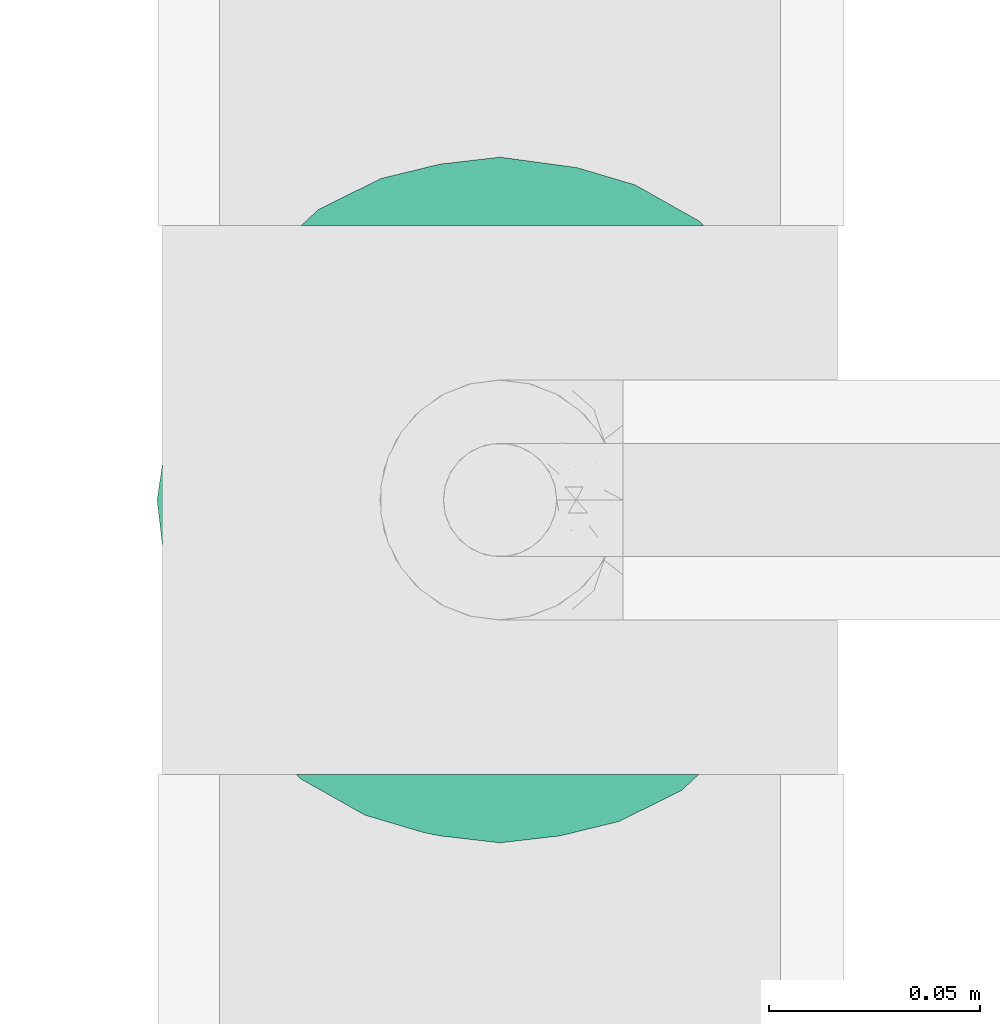
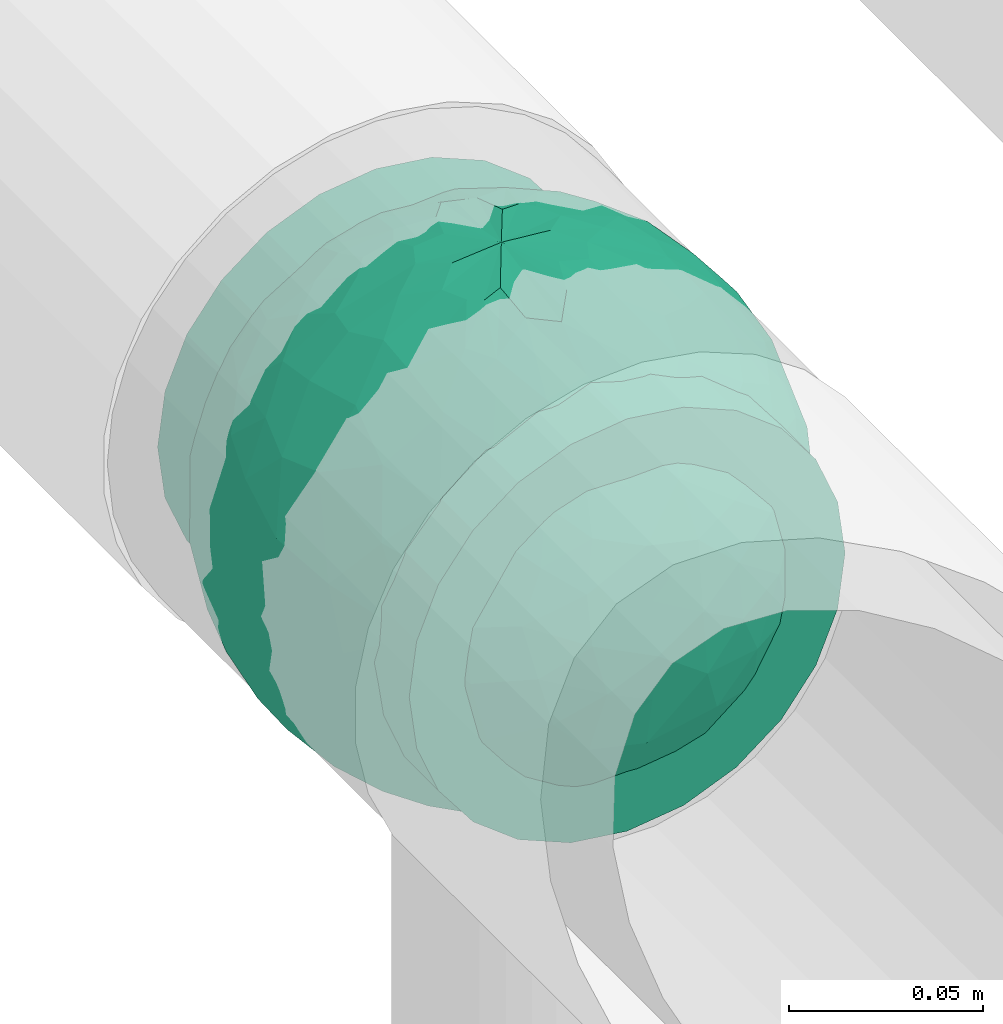
# One storey, part 807 of 827: 1 flow fitting.
"""IFC2X3 building model written with IfcOpenShell, lengths in millimetres."""

from ifc_helpers import new_model, entity, si_unit, converted_unit, derived_unit, direction, frame, origin, place, context, subcontext, project, spatial, faceted_brep, source, transform, mapped, material, material_list, type_object, type_shapes, element, save


model = new_model("IFC2X3")

# Units and contexts
model_context = context("Model", 3, precision=0.01, world=origin(), true_north=direction((6.12303176911189e-17, 1.0)))
body_context = subcontext(model_context, "Body", "Model", "MODEL_VIEW")
ifc_project = project(units=[si_unit("LENGTHUNIT", "METRE", prefix="MILLI"), si_unit("AREAUNIT", "SQUARE_METRE"), si_unit("VOLUMEUNIT", "CUBIC_METRE"), converted_unit("PLANEANGLEUNIT", "DEGREE", entity("IfcRatioMeasure", 0.0174532925199433), si_unit("PLANEANGLEUNIT", "RADIAN"), dimensions=[0, 0, 0, 0, 0, 0, 0]), si_unit("MASSUNIT", "GRAM", prefix="KILO"), derived_unit("MASSDENSITYUNIT", [(si_unit("MASSUNIT", "GRAM", prefix="KILO"), 1), (si_unit("LENGTHUNIT", "METRE"), -3)]), derived_unit("MOMENTOFINERTIAUNIT", [(si_unit("LENGTHUNIT", "METRE"), 4)]), si_unit("TIMEUNIT", "SECOND"), si_unit("FREQUENCYUNIT", "HERTZ"), si_unit("THERMODYNAMICTEMPERATUREUNIT", "DEGREE_CELSIUS"), derived_unit("THERMALTRANSMITTANCEUNIT", [(si_unit("MASSUNIT", "GRAM", prefix="KILO"), 1), (si_unit("THERMODYNAMICTEMPERATUREUNIT", "KELVIN"), -1), (si_unit("TIMEUNIT", "SECOND"), -3)]), derived_unit("VOLUMETRICFLOWRATEUNIT", [(si_unit("LENGTHUNIT", "METRE"), 3), (si_unit("TIMEUNIT", "SECOND"), -1)]), derived_unit("MASSFLOWRATEUNIT", [(si_unit("MASSUNIT", "GRAM", prefix="KILO"), 1), (si_unit("TIMEUNIT", "SECOND"), -1)]), derived_unit("ROTATIONALFREQUENCYUNIT", [(si_unit("TIMEUNIT", "SECOND"), -1)]), si_unit("ELECTRICCURRENTUNIT", "AMPERE"), si_unit("ELECTRICVOLTAGEUNIT", "VOLT"), si_unit("POWERUNIT", "WATT"), si_unit("FORCEUNIT", "NEWTON", prefix="KILO"), si_unit("ILLUMINANCEUNIT", "LUX"), si_unit("LUMINOUSFLUXUNIT", "LUMEN"), si_unit("LUMINOUSINTENSITYUNIT", "CANDELA"), derived_unit("USERDEFINED", [(si_unit("MASSUNIT", "GRAM", prefix="KILO"), -1), (si_unit("LENGTHUNIT", "METRE"), -2), (si_unit("TIMEUNIT", "SECOND"), 3), (si_unit("LUMINOUSFLUXUNIT", "LUMEN"), 1)]), derived_unit("LINEARVELOCITYUNIT", [(si_unit("LENGTHUNIT", "METRE"), 1), (si_unit("TIMEUNIT", "SECOND"), -1)]), si_unit("PRESSUREUNIT", "PASCAL"), derived_unit("USERDEFINED", [(si_unit("LENGTHUNIT", "METRE"), -2), (si_unit("MASSUNIT", "GRAM", prefix="KILO"), 1), (si_unit("TIMEUNIT", "SECOND"), -2)]), derived_unit("LINEARFORCEUNIT", [(si_unit("MASSUNIT", "GRAM", prefix="KILO"), 1), (si_unit("LENGTHUNIT", "METRE"), 1), (si_unit("TIMEUNIT", "SECOND"), -2), (si_unit("LENGTHUNIT", "METRE"), -1)]), derived_unit("PLANARFORCEUNIT", [(si_unit("MASSUNIT", "GRAM", prefix="KILO"), 1), (si_unit("LENGTHUNIT", "METRE"), 1), (si_unit("TIMEUNIT", "SECOND"), -2), (si_unit("LENGTHUNIT", "METRE"), -2)])], contexts=[model_context])

# Site, building, storey
site_placement = place(None, origin())
site = spatial("IfcSite", under=ifc_project, at=site_placement, CompositionType="ELEMENT")
building_placement = place(site_placement, origin())
building = spatial("IfcBuilding", under=site, at=building_placement, CompositionType="ELEMENT")
storey_placement = place(building_placement, frame((0.0, 0.0, 28200.0)))
storey = spatial("IfcBuildingStorey", under=building, at=storey_placement, Name="08", CompositionType="ELEMENT", Elevation=28200.0)

# Flow fitting
ifc_material_1 = material()
ifc_material_2 = material(Name="ADSK_")
ifc_material_list = material_list([ifc_material_1, ifc_material_2])
pipe_fitting_type = type_object("IfcPipeFittingType", Name="ADSK_1", PredefinedType="NOTDEFINED", material=ifc_material_list)
shared_shape = source(origin(), body_context, "Body", "Brep", [
    faceted_brep([(-65.0, 32.5, -56.29), (-65.0, 16.82, -62.79), (-65.0, 0.0, -65.0), (-65.0, -16.82, -62.79), (-65.0, -32.5, -56.29), (-65.0, -45.96, -45.96), (-65.0, -56.29, -32.5), (-65.0, -62.79, -16.82), (-65.0, -65.0, 0.0), (-65.0, -62.79, 16.82), (-65.0, -56.29, 32.5), (-65.0, -45.96, 45.96), (-65.0, -32.5, 56.29), (-65.0, -16.82, 62.79), (-65.0, 0.0, 65.0), (-65.0, 16.82, 62.79), (-65.0, 32.5, 56.29), (-65.0, 45.96, 45.96), (-65.0, 56.29, 32.5), (-65.0, 62.79, 16.82), (-65.0, 65.0, 0.0), (-65.0, 62.79, -16.82), (-65.0, 56.29, -32.5), (-65.0, 45.96, -45.96), (65.0, 0.0, -65.0), (65.0, 16.82, -62.79), (65.0, 32.5, -56.29), (65.0, 45.96, -45.96), (65.0, 56.29, -32.5), (65.0, 62.79, -16.82), (65.0, 65.0, 0.0), (65.0, 62.79, 16.82), (65.0, 56.29, 32.5), (65.0, 45.96, 45.96), (65.0, 32.5, 56.29), (65.0, 16.82, 62.79), (65.0, 0.0, 65.0), (65.0, -16.82, 62.79), (65.0, -32.5, 56.29), (65.0, -45.96, 45.96), (65.0, -56.29, 32.5), (65.0, -62.79, 16.82), (65.0, -65.0, 0.0), (65.0, -62.79, -16.82), (65.0, -56.29, -32.5), (65.0, -45.96, -45.96), (65.0, -32.5, -56.29), (65.0, -16.82, -62.79), (12.5, -65.0, 0.0), (11.74, -64.86, 4.28), (9.57, -64.5, 8.04), (2.17, -63.82, 12.31), (6.26, -64.09, 10.82), (-11.74, -64.86, 4.28), (-9.58, -64.5, 8.03), (-12.5, -65.0, 0.0), (-6.26, -64.09, 10.82), (-2.18, -63.82, 12.31), (2.17, -63.82, -12.31), (6.26, -64.09, -10.82), (11.74, -64.86, -4.28), (9.57, -64.5, -8.04), (-2.18, -63.82, -12.31), (-6.26, -64.09, -10.82), (-9.58, -64.5, -8.03), (-11.74, -64.86, -4.28), (3.24, -70.0, -12.07), (6.25, -70.0, -10.83), (8.84, -70.0, -8.84), (10.83, -70.0, -6.25), (12.07, -70.0, -3.24), (12.5, -70.0, 0.0), (12.07, -70.0, 3.24), (10.83, -70.0, 6.25), (8.84, -70.0, 8.84), (6.25, -70.0, 10.83), (3.24, -70.0, 12.07), (0.0, -70.0, 12.5), (-3.24, -70.0, 12.07), (-6.25, -70.0, 10.83), (-8.84, -70.0, 8.84), (-10.83, -70.0, 6.25), (-12.07, -70.0, 3.24), (-12.5, -70.0, 0.0), (-12.07, -70.0, -3.24), (-10.83, -70.0, -6.25), (-8.84, -70.0, -8.84), (-6.25, -70.0, -10.83), (-3.24, -70.0, -12.07), (0.0, -70.0, -12.5)], [[[0, 1, 2, 3, 4, 5, 6, 7, 8, 9, 10, 11, 12, 13, 14, 15, 16, 17, 18, 19, 20, 21, 22, 23]], [[24, 25, 26, 27, 28, 29, 30, 31, 32, 33, 34, 35, 36, 37, 38, 39, 40, 41, 42, 43, 44, 45, 46, 47]], [[48, 42, 49]], [[50, 49, 42]], [[42, 41, 50]], [[51, 40, 10]], [[52, 41, 51]], [[41, 52, 50]], [[51, 41, 40]], [[40, 39, 11, 10]], [[53, 54, 8]], [[8, 55, 53]], [[54, 9, 8]], [[56, 57, 9]], [[57, 10, 9]], [[57, 51, 10]], [[56, 9, 54]], [[39, 38, 12, 11]], [[14, 13, 37, 36]], [[13, 12, 38, 37]], [[15, 14, 36, 35]], [[32, 31, 19, 18]], [[17, 16, 34, 33]], [[18, 17, 33, 32]], [[35, 34, 16, 15]], [[20, 19, 31, 30]], [[20, 30, 29, 21]], [[22, 28, 27, 23]], [[21, 29, 28, 22]], [[24, 47, 3, 2]], [[1, 0, 26, 25]], [[2, 1, 25, 24]], [[26, 0, 23, 27]], [[46, 4, 3, 47]], [[46, 45, 5, 4]], [[44, 43, 58]], [[6, 44, 58]], [[44, 6, 5, 45]], [[43, 59, 58]], [[42, 48, 60]], [[59, 43, 61]], [[60, 61, 42]], [[61, 43, 42]], [[6, 58, 62]], [[7, 6, 62]], [[62, 63, 7]], [[64, 8, 7]], [[65, 55, 8]], [[65, 8, 64]], [[64, 7, 63]], [[66, 67, 68, 69, 70, 71, 72, 73, 74, 75, 76, 77, 78, 79, 80, 81, 82, 83, 84, 85, 86, 87, 88, 89]], [[83, 82, 55]], [[80, 79, 53]], [[81, 80, 53]], [[82, 81, 53]], [[55, 82, 53]], [[53, 79, 54]], [[57, 56, 52]], [[54, 77, 56]], [[78, 77, 54]], [[78, 54, 79]], [[76, 75, 50]], [[77, 76, 50]], [[73, 72, 49]], [[74, 73, 49]], [[75, 74, 49]], [[77, 50, 52]], [[51, 57, 52]], [[72, 48, 49]], [[49, 50, 75]], [[72, 71, 48]], [[52, 56, 77]], [[71, 70, 48]], [[68, 67, 60]], [[69, 68, 60]], [[70, 69, 60]], [[48, 70, 60]], [[60, 67, 61]], [[58, 59, 62]], [[61, 89, 59]], [[66, 89, 61]], [[66, 61, 67]], [[88, 87, 64]], [[89, 88, 64]], [[85, 84, 65]], [[86, 85, 65]], [[87, 86, 65]], [[89, 64, 63]], [[62, 59, 63]], [[84, 55, 65]], [[65, 64, 87]], [[84, 83, 55]], [[63, 59, 89]]]),
    faceted_brep([(-26.57, 76.36, -8.07), (-32.83, 71.49, -20.33), (-47.03, 64.85, -13.55), (22.24, -77.88, -6.48), (0.0, -81.25, 0.0), (14.57, -79.42, -9.02), (-19.55, 43.65, -65.68), (-6.7, 41.88, -69.3), (-15.5, 23.94, -76.08), (15.55, -78.16, 0.0), (20.63, -67.73, -39.86), (17.31, -55.39, -56.87), (33.39, -55.07, -49.54), (6.89, -77.99, -21.73), (13.76, -77.98, -18.22), (0.0, -79.9, -14.73), (-69.67, 30.72, -28.35), (-63.35, 45.14, -23.48), (-60.56, 38.81, -37.79), (-44.27, 66.26, 0.0), (8.9, -68.68, -42.49), (0.0, -57.53, -57.37), (-48.93, 45.14, -46.58), (-49.03, 57.11, -30.6), (-35.46, 62.54, -37.85), (76.18, -1.07, -28.23), (78.6, -12.72, -16.17), (71.53, -15.85, -35.12), (10.46, 67.82, -43.51), (0.0, 75.3, -30.53), (6.86, 78.01, -21.66), (-10.53, -67.73, -43.64), (0.0, -75.25, -30.63), (-6.89, -77.99, -21.73), (0.0, 81.25, 0.0), (15.55, 78.16, 0.0), (22.61, 77.77, -6.46), (-12.72, -56.34, -57.14), (-5.46, -45.53, -67.07), (44.37, 62.32, -27.38), (43.44, 67.56, -12.26), (56.18, 55.82, -18.18), (-13.79, 77.96, -18.26), (-25.89, 72.59, -25.72), (-16.58, 78.16, -14.76), (75.07, 31.09, 0.0), (74.86, 27.47, -15.59), (67.53, 42.93, -14.07), (13.79, 77.96, -18.26), (12.84, 79.64, -9.7), (21.38, 75.85, -19.79), (74.72, 15.85, -27.69), (79.59, 7.96, -14.27), (43.73, -67.56, -11.18), (57.45, -57.45, 0.0), (44.27, -66.26, 0.0), (63.35, -45.14, -23.48), (61.82, -51.54, -11.09), (49.12, -59.87, -24.59), (78.16, 15.55, 0.0), (50.83, -12.03, -62.24), (35.62, -9.55, -72.4), (43.7, 11.32, -67.56), (72.48, -29.04, -22.46), (-44.38, -62.32, -27.37), (-26.83, -74.87, -16.61), (-43.44, -67.56, -12.26), (-13.76, -77.98, -18.22), (-12.85, -79.64, -9.7), (-21.39, -75.84, -19.81), (-2.49, -31.04, -75.05), (8.59, -44.22, -67.62), (-74.72, -15.85, -27.69), (-68.67, -30.94, -30.47), (-74.55, -27.6, -16.8), (-75.07, 31.09, 0.0), (-71.41, 36.12, -14.04), (-75.88, 22.59, -18.27), (-22.61, -77.77, -6.46), (-16.87, -79.04, -8.34), (28.21, -26.53, -71.43), (13.03, -29.67, -74.51), (18.2, -9.78, -78.58), (-56.42, -55.66, -17.92), (6.0, 45.8, -66.84), (0.0, 57.69, -57.22), (-78.16, -15.55, 0.0), (-79.59, -7.96, -14.27), (32.83, -71.49, -20.33), (-15.55, -78.16, 0.0), (-20.62, 67.82, -39.72), (-33.11, 50.34, -54.51), (-61.82, 51.54, -11.09), (-66.26, 44.27, 0.0), (75.07, -31.09, 0.0), (66.26, -44.27, 0.0), (-6.86, 78.01, -21.66), (0.0, 79.92, -14.67), (26.82, 74.88, -16.61), (16.85, 79.04, -8.33), (-8.98, 69.99, -40.29), (38.78, -61.98, -35.46), (48.93, -45.14, -46.58), (55.26, -48.62, -34.41), (-71.53, 15.85, -35.12), (-78.76, 7.96, -18.29), (-17.06, 58.9, -53.31), (-15.55, 78.16, 0.0), (13.32, 55.85, -57.49), (21.86, 61.99, -47.75), (-15.13, 79.31, -9.05), (26.19, -72.28, -26.28), (17.27, -77.87, -15.49), (-29.57, -28.73, -70.02), (-26.25, -43.22, -63.6), (-42.18, -36.82, -58.88), (41.25, 41.74, -56.2), (54.79, 33.3, -49.91), (40.91, 28.53, -64.14), (38.98, -38.31, -60.12), (52.67, -28.88, -54.71), (68.84, 3.22, -43.04), (66.02, 21.29, -42.31), (-42.82, 33.53, -60.37), (-55.21, 10.46, -58.69), (-57.08, 27.98, -50.61), (-56.33, -15.85, -56.37), (-55.8, -33.3, -48.77), (-66.18, -20.5, -42.45), (31.09, 75.07, 0.0), (44.27, 66.26, 0.0), (57.45, 57.45, 0.0), (-31.09, -75.07, 0.0), (-57.45, -57.45, 0.0), (1.56, 67.82, -44.72), (-1.57, -67.73, -44.86), (22.55, 72.77, -28.25), (16.53, 72.17, -33.48), (-22.52, -72.77, -28.27), (-16.58, -72.47, -32.79), (28.96, -66.23, -37.11), (62.57, -34.08, -39.05), (62.37, -15.41, -49.74), (68.82, 31.09, -29.97), (-66.06, -1.38, -47.28), (-67.87, -42.27, -14.43), (29.1, 65.34, -38.54), (33.22, 68.08, -29.37), (46.02, 49.13, -45.5), (10.35, 15.34, -79.12), (0.0, 0.22, -81.25), (-29.12, -65.31, -38.57), (-22.07, -61.55, -48.23), (-33.19, -68.12, -29.33), (-46.02, -49.17, -45.45), (-34.11, 19.17, -71.21), (-23.02, 4.97, -77.76), (-40.38, 0.85, -70.5), (2.47, 31.35, -74.92), (16.3, 35.47, -71.26), (-13.73, -8.11, -79.67), (-28.12, -13.42, -75.04), (33.83, 54.01, -50.4), (26.1, 43.46, -63.49), (24.94, -42.3, -64.73), (-16.13, -35.64, -71.21), (0.28, -15.85, -79.69), (-13.57, -22.47, -76.89), (60.35, 45.14, -30.37), (-60.34, -45.14, -30.38), (-33.99, -54.1, -50.2), (-57.45, 57.45, 0.0), (-42.67, -18.04, -66.75), (-63.99, 15.14, -47.72), (-81.25, 0.0, 0.0), (-78.16, 15.55, 0.0), (-74.66, 0.0, -32.06), (-31.09, 75.07, 0.0), (31.09, -75.07, 0.0), (56.37, 15.85, -56.33), (28.0, 13.82, -75.01), (66.26, 44.27, 0.0), (81.25, 0.0, 0.0), (78.16, -15.55, 0.0), (-66.26, -44.27, 0.0), (-75.07, -31.09, 0.0), (-44.27, -66.26, 0.0), (26.57, 76.36, 8.07), (32.83, 71.49, 20.33), (47.03, 64.85, 13.55), (-22.24, -77.88, 6.48), (-14.57, -79.42, 9.02), (19.55, 43.65, 65.68), (6.7, 41.88, 69.3), (15.5, 23.94, 76.08), (-20.63, -67.73, 39.86), (-17.31, -55.39, 56.87), (-33.39, -55.07, 49.54), (-6.89, -77.99, 21.73), (-13.76, -77.98, 18.22), (0.0, -79.9, 14.73), (69.67, 30.72, 28.35), (63.35, 45.14, 23.48), (60.56, 38.81, 37.79), (-8.9, -68.68, 42.49), (0.0, -57.53, 57.37), (48.93, 45.14, 46.58), (49.03, 57.11, 30.6), (35.46, 62.54, 37.85), (-76.18, -1.07, 28.23), (-78.6, -12.72, 16.17), (-71.53, -15.85, 35.12), (-10.46, 67.82, 43.51), (0.0, 75.3, 30.53), (-6.86, 78.01, 21.66), (10.53, -67.73, 43.64), (0.0, -75.25, 30.63), (6.89, -77.99, 21.73), (-22.61, 77.77, 6.46), (12.72, -56.34, 57.14), (5.46, -45.53, 67.07), (-44.37, 62.32, 27.38), (-43.44, 67.56, 12.26), (-56.18, 55.82, 18.18), (13.79, 77.96, 18.26), (25.89, 72.59, 25.72), (16.58, 78.16, 14.76), (-74.86, 27.47, 15.59), (-67.53, 42.93, 14.07), (-13.79, 77.96, 18.26), (-12.84, 79.64, 9.7), (-21.38, 75.85, 19.79), (-74.72, 15.85, 27.69), (-79.59, 7.96, 14.27), (-43.73, -67.56, 11.18), (-63.35, -45.14, 23.48), (-61.82, -51.54, 11.09), (-49.12, -59.87, 24.59), (-50.83, -12.03, 62.24), (-35.62, -9.55, 72.4), (-43.7, 11.32, 67.56), (-72.48, -29.04, 22.46), (44.38, -62.32, 27.37), (26.83, -74.87, 16.61), (43.44, -67.56, 12.26), (13.76, -77.98, 18.22), (12.85, -79.64, 9.7), (21.39, -75.84, 19.81), (2.49, -31.04, 75.05), (-8.59, -44.22, 67.62), (74.72, -15.85, 27.69), (68.67, -30.94, 30.47), (74.55, -27.6, 16.8), (71.41, 36.12, 14.04), (75.88, 22.59, 18.27), (22.61, -77.77, 6.46), (16.87, -79.04, 8.34), (-28.21, -26.53, 71.43), (-13.03, -29.67, 74.51), (-18.2, -9.78, 78.58), (56.42, -55.66, 17.92), (-6.0, 45.8, 66.84), (0.0, 57.69, 57.22), (78.78, -14.01, 14.13), (-32.83, -71.49, 20.33), (20.62, 67.82, 39.72), (33.11, 50.34, 54.51), (61.82, 51.54, 11.09), (6.86, 78.01, 21.66), (0.0, 79.92, 14.67), (-26.82, 74.88, 16.61), (-16.85, 79.04, 8.33), (8.98, 69.99, 40.29), (-38.78, -61.98, 35.46), (-48.93, -45.14, 46.58), (-55.26, -48.62, 34.41), (71.53, 15.85, 35.12), (78.76, 7.96, 18.29), (17.06, 58.9, 53.31), (-13.32, 55.85, 57.49), (-21.86, 61.99, 47.75), (15.13, 79.31, 9.05), (-26.19, -72.28, 26.28), (-17.27, -77.87, 15.49), (29.57, -28.73, 70.02), (26.25, -43.22, 63.6), (42.18, -36.82, 58.88), (-41.25, 41.74, 56.2), (-54.79, 33.3, 49.91), (-40.91, 28.53, 64.14), (-38.98, -38.31, 60.12), (-52.67, -28.88, 54.71), (-68.84, 3.22, 43.04), (-66.02, 21.29, 42.31), (42.82, 33.53, 60.37), (55.21, 10.46, 58.69), (57.08, 27.98, 50.61), (56.33, -15.85, 56.37), (55.8, -33.3, 48.77), (66.18, -20.5, 42.45), (-1.56, 67.82, 44.72), (1.57, -67.73, 44.86), (-22.55, 72.77, 28.25), (-16.53, 72.17, 33.48), (22.52, -72.77, 28.27), (16.58, -72.47, 32.79), (-28.96, -66.23, 37.11), (-62.57, -34.08, 39.05), (-62.37, -15.41, 49.74), (-68.82, 31.09, 29.97), (66.06, -1.38, 47.28), (67.87, -42.27, 14.43), (-29.1, 65.34, 38.54), (-33.22, 68.08, 29.37), (-46.02, 49.13, 45.5), (-10.35, 15.34, 79.12), (0.0, 0.22, 81.25), (29.12, -65.31, 38.57), (22.07, -61.55, 48.23), (33.19, -68.12, 29.33), (46.02, -49.17, 45.45), (34.11, 19.17, 71.21), (23.02, 4.97, 77.76), (40.38, 0.85, 70.5), (-2.47, 31.35, 74.92), (-16.3, 35.47, 71.26), (13.73, -8.11, 79.67), (28.12, -13.42, 75.04), (-33.83, 54.01, 50.4), (-26.1, 43.46, 63.49), (-24.94, -42.3, 64.73), (16.13, -35.64, 71.21), (-0.28, -15.85, 79.69), (13.57, -22.47, 76.89), (-60.35, 45.14, 30.37), (60.34, -45.14, 30.38), (33.99, -54.1, 50.2), (42.67, -18.04, 66.75), (63.99, 15.14, 47.72), (74.66, 0.0, 32.06), (-56.37, 15.85, 56.33), (-28.0, 13.82, 75.01)], [[[0, 1, 2]], [[3, 4, 5]], [[6, 7, 8]], [[4, 3, 9]], [[10, 11, 12]], [[13, 14, 4]], [[13, 4, 15]], [[16, 17, 18]], [[19, 0, 2]], [[20, 21, 11]], [[22, 23, 24]], [[25, 26, 27]], [[28, 29, 30]], [[31, 32, 33]], [[34, 35, 36]], [[37, 38, 21]], [[39, 40, 41]], [[42, 43, 44]], [[45, 46, 47]], [[30, 34, 48]], [[49, 50, 48]], [[51, 46, 52]], [[53, 54, 55]], [[56, 57, 58]], [[46, 59, 52]], [[60, 61, 62]], [[27, 26, 63]], [[64, 65, 66]], [[67, 68, 69]], [[38, 70, 71]], [[72, 73, 74]], [[15, 33, 32]], [[75, 76, 77]], [[78, 65, 79]], [[80, 81, 82]], [[64, 66, 83]], [[84, 7, 85]], [[74, 86, 87]], [[88, 53, 3]], [[4, 89, 78]], [[24, 90, 91]], [[92, 76, 93]], [[94, 95, 63]], [[96, 34, 97]], [[36, 98, 99]], [[96, 42, 34]], [[96, 100, 90]], [[101, 102, 103]], [[77, 104, 105]], [[90, 106, 91]], [[34, 0, 107]], [[84, 85, 108]], [[109, 108, 28]], [[0, 110, 1]], [[14, 111, 112]], [[97, 30, 29]], [[39, 98, 40]], [[67, 33, 4]], [[113, 114, 115]], [[116, 117, 118]], [[119, 60, 120]], [[121, 122, 51]], [[123, 124, 125]], [[126, 127, 128]], [[129, 40, 36]], [[130, 131, 40]], [[132, 66, 78]], [[133, 83, 66]], [[97, 29, 96]], [[28, 108, 134]], [[100, 96, 29]], [[44, 34, 42]], [[15, 32, 13]], [[32, 31, 135]], [[20, 13, 32]], [[112, 4, 14]], [[48, 136, 137]], [[96, 90, 42]], [[90, 24, 43]], [[68, 67, 4]], [[67, 138, 139]], [[13, 10, 14]], [[140, 101, 111]], [[53, 58, 57]], [[141, 102, 120]], [[27, 142, 121]], [[46, 51, 143]], [[23, 2, 1]], [[125, 18, 22]], [[124, 126, 144]], [[73, 145, 74]], [[30, 137, 28]], [[28, 137, 109]], [[146, 147, 148]], [[149, 150, 8]], [[151, 152, 139]], [[152, 114, 37]], [[151, 153, 154]], [[155, 156, 157]], [[158, 84, 159]], [[156, 8, 150]], [[156, 160, 161]], [[155, 124, 123]], [[162, 116, 163]], [[119, 80, 60]], [[12, 102, 101]], [[81, 164, 71]], [[91, 123, 22]], [[100, 106, 90]], [[70, 38, 165]], [[81, 70, 166]], [[167, 113, 161]], [[156, 161, 157]], [[131, 47, 41]], [[36, 40, 98]], [[148, 39, 168]], [[146, 136, 147]], [[143, 117, 168]], [[146, 162, 109]], [[99, 34, 36]], [[133, 145, 83]], [[78, 66, 65]], [[154, 64, 169]], [[151, 138, 153]], [[115, 127, 126]], [[151, 170, 152]], [[79, 4, 78]], [[134, 100, 29]], [[85, 7, 106]], [[85, 106, 100]], [[91, 106, 6]], [[123, 6, 155]], [[91, 22, 24]], [[22, 18, 23]], [[43, 24, 1]], [[92, 17, 76]], [[1, 24, 23]], [[17, 2, 23]], [[92, 171, 2]], [[110, 0, 34]], [[6, 123, 91]], [[157, 161, 172]], [[144, 126, 128]], [[123, 125, 22]], [[124, 173, 125]], [[104, 16, 18]], [[18, 125, 173]], [[23, 18, 17]], [[105, 174, 175]], [[76, 17, 16]], [[105, 176, 87]], [[77, 175, 75]], [[176, 105, 104]], [[77, 76, 16]], [[76, 75, 93]], [[93, 171, 92]], [[177, 0, 19]], [[2, 17, 92]], [[104, 77, 16]], [[175, 77, 105]], [[3, 53, 178]], [[53, 88, 58]], [[88, 3, 5]], [[101, 58, 88]], [[56, 103, 141]], [[111, 101, 88]], [[101, 140, 12]], [[10, 20, 11]], [[119, 102, 12]], [[71, 70, 81]], [[119, 164, 80]], [[164, 12, 11]], [[80, 82, 61]], [[51, 25, 121]], [[119, 120, 102]], [[13, 20, 10]], [[20, 32, 135]], [[60, 142, 120]], [[56, 58, 103]], [[142, 141, 120]], [[63, 141, 27]], [[121, 60, 179]], [[141, 142, 27]], [[60, 121, 142]], [[122, 121, 179]], [[117, 122, 179]], [[143, 51, 122]], [[117, 179, 118]], [[168, 117, 148]], [[62, 118, 179]], [[159, 118, 180]], [[117, 143, 122]], [[143, 168, 47]], [[41, 47, 168]], [[47, 131, 181]], [[47, 46, 143]], [[46, 45, 59]], [[59, 182, 52]], [[26, 52, 182]], [[25, 51, 52]], [[26, 182, 183]], [[95, 57, 63]], [[26, 25, 52]], [[121, 25, 27]], [[94, 63, 26]], [[141, 63, 56]], [[53, 57, 54]], [[54, 57, 95]], [[63, 57, 56]], [[39, 41, 168]], [[41, 40, 131]], [[12, 164, 119]], [[164, 11, 71]], [[11, 21, 71]], [[38, 71, 21]], [[21, 135, 37]], [[38, 37, 165]], [[152, 37, 31]], [[165, 37, 114]], [[139, 31, 33]], [[151, 154, 170]], [[31, 139, 152]], [[67, 139, 33]], [[113, 165, 114]], [[167, 161, 160]], [[114, 170, 115]], [[172, 161, 113]], [[127, 115, 154]], [[172, 115, 126]], [[115, 172, 113]], [[157, 126, 124]], [[126, 157, 172]], [[124, 155, 157]], [[8, 156, 155]], [[160, 156, 150]], [[6, 8, 155]], [[8, 158, 149]], [[154, 169, 127]], [[128, 73, 72]], [[73, 127, 169]], [[176, 144, 128]], [[176, 128, 72]], [[173, 144, 104]], [[115, 170, 154]], [[114, 152, 170]], [[127, 73, 128]], [[73, 169, 145]], [[83, 145, 169]], [[145, 133, 184]], [[145, 185, 74]], [[74, 185, 86]], [[87, 86, 174]], [[105, 87, 174]], [[74, 87, 72]], [[64, 83, 169]], [[66, 132, 186]], [[167, 166, 70]], [[164, 81, 80]], [[149, 82, 150]], [[80, 61, 60]], [[82, 180, 61]], [[62, 180, 118]], [[112, 88, 5]], [[140, 14, 10]], [[166, 160, 150]], [[165, 167, 70]], [[150, 82, 166]], [[81, 166, 82]], [[167, 165, 113]], [[166, 167, 160]], [[88, 112, 111]], [[4, 112, 5]], [[144, 176, 104]], [[87, 176, 72]], [[101, 103, 58]], [[102, 141, 103]], [[60, 62, 179]], [[61, 180, 62]], [[14, 140, 111]], [[12, 140, 10]], [[48, 137, 30]], [[109, 137, 146]], [[162, 146, 148]], [[108, 85, 134]], [[109, 163, 108]], [[163, 159, 84]], [[116, 162, 148]], [[163, 109, 162]], [[163, 84, 108]], [[7, 84, 158]], [[118, 159, 163]], [[149, 159, 180]], [[8, 7, 158]], [[7, 6, 106]], [[117, 116, 148]], [[163, 116, 118]], [[98, 49, 99]], [[50, 49, 98]], [[34, 49, 48]], [[147, 98, 39]], [[136, 48, 50]], [[147, 39, 148]], [[137, 136, 146]], [[136, 50, 147]], [[98, 147, 50]], [[34, 99, 49]], [[65, 68, 79]], [[68, 65, 69]], [[153, 65, 64]], [[138, 67, 69]], [[153, 64, 154]], [[139, 138, 151]], [[138, 69, 153]], [[65, 153, 69]], [[4, 79, 68]], [[34, 30, 97]], [[4, 33, 15]], [[100, 134, 85]], [[29, 28, 134]], [[37, 135, 31]], [[20, 135, 21]], [[159, 149, 158]], [[82, 149, 180]], [[40, 129, 130]], [[186, 133, 66]], [[44, 1, 110]], [[90, 43, 42]], [[1, 44, 43]], [[34, 44, 110]], [[2, 171, 19]], [[0, 177, 107]], [[144, 173, 124]], [[18, 173, 104]], [[3, 178, 9]], [[55, 178, 53]], [[181, 45, 47]], [[94, 26, 183]], [[184, 185, 145]], [[35, 129, 36]], [[89, 132, 78]], [[187, 188, 189]], [[190, 4, 191]], [[192, 193, 194]], [[4, 190, 89]], [[195, 196, 197]], [[198, 199, 4]], [[198, 4, 200]], [[201, 202, 203]], [[130, 187, 189]], [[204, 205, 196]], [[206, 207, 208]], [[209, 210, 211]], [[212, 213, 214]], [[215, 216, 217]], [[34, 107, 218]], [[219, 220, 205]], [[221, 222, 223]], [[224, 225, 226]], [[75, 227, 228]], [[214, 34, 229]], [[230, 231, 229]], [[232, 227, 233]], [[234, 133, 186]], [[235, 236, 237]], [[227, 175, 233]], [[238, 239, 240]], [[211, 210, 241]], [[242, 243, 244]], [[245, 246, 247]], [[220, 248, 249]], [[250, 251, 252]], [[200, 217, 216]], [[45, 253, 254]], [[255, 243, 256]], [[257, 258, 259]], [[242, 244, 260]], [[261, 193, 262]], [[252, 183, 263]], [[264, 234, 190]], [[4, 9, 255]], [[208, 265, 266]], [[267, 253, 181]], [[185, 184, 241]], [[268, 34, 269]], [[218, 270, 271]], [[268, 224, 34]], [[268, 272, 265]], [[273, 274, 275]], [[254, 276, 277]], [[265, 278, 266]], [[34, 187, 35]], [[261, 262, 279]], [[280, 279, 212]], [[187, 281, 188]], [[199, 282, 283]], [[269, 214, 213]], [[221, 270, 222]], [[245, 217, 4]], [[284, 285, 286]], [[287, 288, 289]], [[290, 238, 291]], [[292, 293, 232]], [[294, 295, 296]], [[297, 298, 299]], [[177, 222, 218]], [[171, 223, 222]], [[178, 244, 255]], [[54, 260, 244]], [[269, 213, 268]], [[34, 230, 229]], [[212, 279, 300]], [[272, 268, 213]], [[226, 34, 224]], [[200, 216, 198]], [[216, 215, 301]], [[204, 198, 216]], [[229, 302, 303]], [[268, 265, 224]], [[265, 208, 225]], [[246, 245, 4]], [[245, 304, 305]], [[198, 195, 199]], [[306, 273, 282]], [[234, 237, 236]], [[307, 274, 291]], [[211, 308, 292]], [[227, 232, 309]], [[207, 189, 188]], [[296, 203, 206]], [[295, 297, 310]], [[251, 311, 252]], [[214, 303, 212]], [[212, 303, 280]], [[312, 313, 314]], [[315, 316, 194]], [[317, 318, 305]], [[318, 285, 219]], [[317, 319, 320]], [[321, 322, 323]], [[324, 261, 325]], [[322, 194, 316]], [[322, 326, 327]], [[321, 295, 294]], [[328, 287, 329]], [[290, 257, 238]], [[197, 274, 273]], [[258, 330, 249]], [[266, 294, 206]], [[272, 278, 265]], [[248, 220, 331]], [[258, 248, 332]], [[333, 284, 327]], [[322, 327, 323]], [[171, 228, 223]], [[218, 222, 270]], [[314, 221, 334]], [[312, 302, 313]], [[309, 288, 334]], [[312, 328, 280]], [[271, 34, 218]], [[54, 311, 260]], [[255, 244, 243]], [[320, 242, 335]], [[317, 304, 319]], [[286, 298, 297]], [[317, 336, 318]], [[256, 4, 255]], [[300, 272, 213]], [[262, 193, 278]], [[262, 278, 272]], [[266, 278, 192]], [[294, 192, 321]], [[266, 206, 208]], [[206, 203, 207]], [[225, 208, 188]], [[267, 202, 253]], [[188, 208, 207]], [[202, 189, 207]], [[267, 131, 189]], [[281, 187, 34]], [[192, 294, 266]], [[323, 327, 337]], [[310, 297, 299]], [[294, 296, 206]], [[295, 338, 296]], [[276, 201, 203]], [[203, 296, 338]], [[207, 203, 202]], [[277, 182, 59]], [[253, 202, 201]], [[263, 250, 252]], [[254, 59, 45]], [[339, 277, 276]], [[254, 253, 201]], [[253, 45, 181]], [[181, 131, 267]], [[129, 187, 130]], [[189, 202, 267]], [[276, 254, 201]], [[59, 254, 277]], [[190, 234, 132]], [[234, 264, 237]], [[272, 300, 262]], [[264, 190, 191]], [[273, 237, 264]], [[235, 275, 307]], [[282, 273, 264]], [[273, 306, 197]], [[195, 204, 196]], [[290, 274, 197]], [[249, 248, 258]], [[290, 330, 257]], [[330, 197, 196]], [[257, 259, 239]], [[232, 209, 292]], [[290, 291, 274]], [[198, 204, 195]], [[204, 216, 301]], [[238, 308, 291]], [[235, 237, 275]], [[308, 307, 291]], [[241, 307, 211]], [[292, 238, 340]], [[307, 308, 211]], [[238, 292, 308]], [[293, 292, 340]], [[288, 293, 340]], [[309, 232, 293]], [[288, 340, 289]], [[334, 288, 314]], [[240, 289, 340]], [[325, 289, 341]], [[288, 309, 293]], [[309, 334, 228]], [[223, 228, 334]], [[228, 171, 93]], [[228, 227, 309]], [[227, 75, 175]], [[175, 174, 233]], [[210, 233, 174]], [[209, 232, 233]], [[210, 174, 86]], [[184, 236, 241]], [[210, 209, 233]], [[292, 209, 211]], [[185, 241, 210]], [[307, 241, 235]], [[234, 236, 133]], [[133, 236, 184]], [[241, 236, 235]], [[221, 223, 334]], [[222, 177, 19]], [[197, 330, 290]], [[330, 196, 249]], [[196, 205, 249]], [[220, 249, 205]], [[205, 301, 219]], [[220, 219, 331]], [[318, 219, 215]], [[331, 219, 285]], [[305, 215, 217]], [[317, 320, 336]], [[215, 305, 318]], [[245, 305, 217]], [[284, 331, 285]], [[333, 327, 326]], [[285, 336, 286]], [[337, 327, 284]], [[298, 286, 320]], [[337, 286, 297]], [[286, 337, 284]], [[323, 297, 295]], [[297, 323, 337]], [[295, 321, 323]], [[194, 322, 321]], [[326, 322, 316]], [[192, 194, 321]], [[194, 324, 315]], [[320, 335, 298]], [[299, 251, 250]], [[251, 298, 335]], [[339, 310, 299]], [[339, 299, 250]], [[338, 310, 276]], [[286, 336, 320]], [[285, 318, 336]], [[298, 251, 299]], [[251, 335, 311]], [[260, 311, 335]], [[311, 54, 95]], [[311, 94, 252]], [[252, 94, 183]], [[182, 277, 263]], [[182, 263, 183]], [[339, 263, 277]], [[242, 260, 335]], [[244, 178, 55]], [[333, 332, 248]], [[330, 258, 257]], [[315, 259, 316]], [[257, 239, 238]], [[259, 341, 239]], [[240, 341, 289]], [[283, 264, 191]], [[306, 199, 195]], [[332, 326, 316]], [[331, 333, 248]], [[316, 259, 332]], [[258, 332, 259]], [[333, 331, 284]], [[332, 333, 326]], [[264, 283, 282]], [[4, 283, 191]], [[310, 339, 276]], [[263, 339, 250]], [[273, 275, 237]], [[274, 307, 275]], [[238, 240, 340]], [[239, 341, 240]], [[199, 306, 282]], [[197, 306, 195]], [[229, 303, 214]], [[280, 303, 312]], [[328, 312, 314]], [[279, 262, 300]], [[280, 329, 279]], [[329, 325, 261]], [[287, 328, 314]], [[329, 280, 328]], [[329, 261, 279]], [[193, 261, 324]], [[289, 325, 329]], [[315, 325, 341]], [[194, 193, 324]], [[193, 192, 278]], [[288, 287, 314]], [[329, 287, 289]], [[270, 230, 271]], [[231, 230, 270]], [[313, 270, 221]], [[302, 229, 231]], [[313, 221, 314]], [[303, 302, 312]], [[302, 231, 313]], [[270, 313, 231]], [[34, 271, 230]], [[243, 246, 256]], [[246, 243, 247]], [[319, 243, 242]], [[304, 245, 247]], [[319, 242, 320]], [[305, 304, 317]], [[304, 247, 319]], [[243, 319, 247]], [[4, 256, 246]], [[34, 214, 269]], [[4, 217, 200]], [[4, 199, 283]], [[213, 212, 300]], [[219, 301, 215]], [[204, 301, 205]], [[325, 315, 324]], [[259, 315, 341]], [[19, 171, 222]], [[55, 54, 244]], [[226, 188, 281]], [[265, 225, 224]], [[188, 226, 225]], [[34, 226, 281]], [[189, 131, 130]], [[187, 129, 35]], [[310, 338, 295]], [[203, 338, 276]], [[190, 132, 89]], [[186, 132, 234]], [[93, 75, 228]], [[185, 210, 86]], [[95, 94, 311]], [[107, 177, 218]], [[9, 178, 255]]]),
])
type_shapes(pipe_fitting_type, [shared_shape])
flow_fitting_placement = place(storey_placement, frame((60158.54, 17147.79, 2900.0), z_axis=(1.0, 0.0, 0.0), x_axis=(0.0, 1.0, 0.0)))
element("IfcFlowFitting", 1, at=flow_fitting_placement, inside=storey, type_object=pipe_fitting_type, material=ifc_material_list, Name="ADSK_1", ObjectType="ADSK_1", context=body_context, shape_type="MappedRepresentation", body=[
    mapped(shared_shape, transform((0.0, 0.0, 0.0), scale=1.0)),
])

save(model, "model.ifc")
